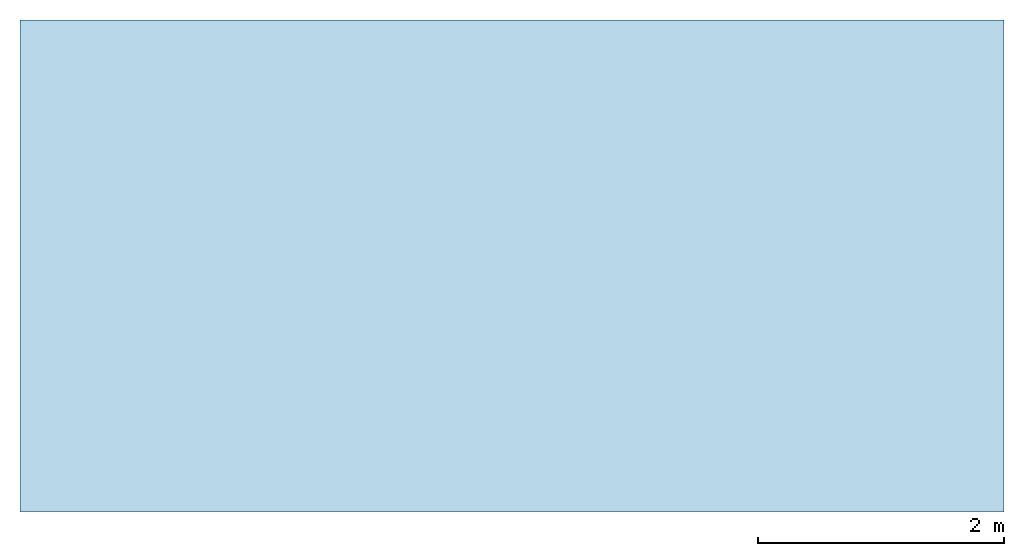
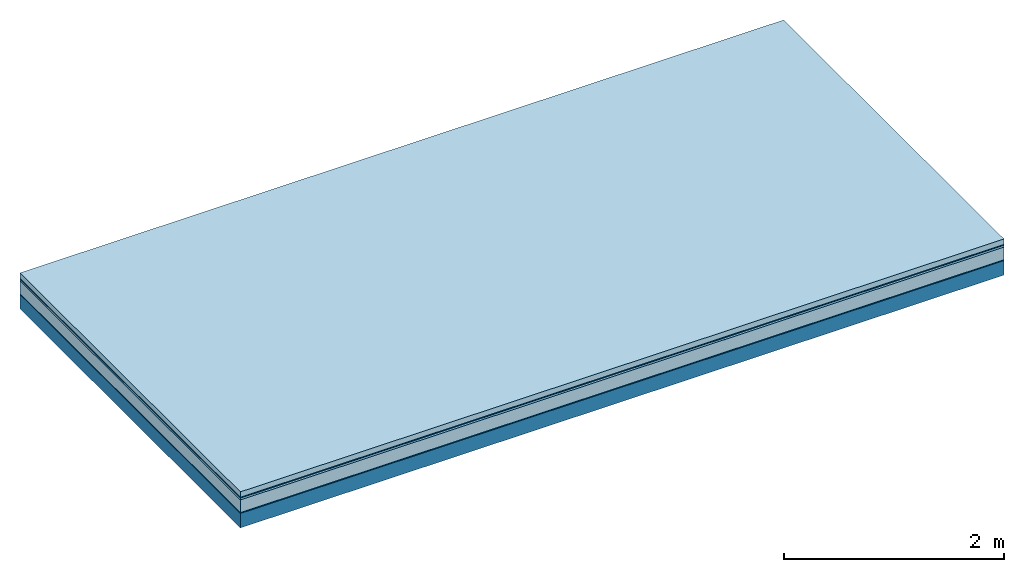
# One storey: 5 plates, 1 member, 1 element without a shape of its own.
"""IFC4 building model written with IfcOpenShell, lengths in metres."""

from ifc_helpers import new_model, si_unit, derived_unit, direction, frame, frame_2d, origin, origin_with_axes, place, context, project, spatial, rectangle, extrude, material, layer, layer_set, type_object, element, aggregate, save


model = new_model("IFC4")

# Units and contexts
plan_context = context("Plan", 3, precision=1e-05, world=origin(), true_north=direction((0.0, 1.0)))
model_context = context("Model", 3, precision=1e-05, world=origin(), true_north=direction((0.0, 1.0)))
ifc_project = project(units=[si_unit("LENGTHUNIT", "METRE"), derived_unit("SOUNDPRESSUREUNIT", [(si_unit("PRESSUREUNIT", "PASCAL", prefix="MICRO"), 0)]), si_unit("ENERGYUNIT", "JOULE", prefix="MEGA"), si_unit("MASSUNIT", "GRAM", prefix="KILO"), derived_unit("THERMALTRANSMITTANCEUNIT", [(si_unit("POWERUNIT", "WATT"), 1), (si_unit("AREAUNIT", "SQUARE_METRE"), -1), (si_unit("THERMODYNAMICTEMPERATUREUNIT", "KELVIN"), -1)]), derived_unit("AREADENSITYUNIT", [(si_unit("MASSUNIT", "GRAM", prefix="KILO"), 1), (si_unit("AREAUNIT", "SQUARE_METRE"), -1)]), derived_unit("USERDEFINED", [(si_unit("ENERGYUNIT", "JOULE", prefix="MEGA"), 1), (si_unit("AREAUNIT", "SQUARE_METRE"), -1)])], contexts=[plan_context, model_context])

# Site, building, storey
site = spatial("IfcSite", under=ifc_project)
building_placement = place(None, origin())
building = spatial("IfcBuilding", under=site, at=building_placement)
storey_placement = place(building_placement, origin())
storey = spatial("IfcBuildingStorey", under=building, at=storey_placement)

# Slab, member, plates
ifc_material_1 = material(Name="clay", Category="02.004")
ifc_layer_1 = layer(ifc_material_1, 0.06, Name="Use and protection layer 2")
ifc_material_2 = material(Name="Protective layer", Category="09.007")
ifc_layer_2 = layer(ifc_material_2, 0.01, Name="Use and protection layer 1")
ifc_material_3 = material(Name="Bituminous", Category="09.003")
ifc_layer_3 = layer(ifc_material_3, 0.02, Name="Seal")
ifc_material_4 = material(Name="Mineral wool", Category="10.008")
ifc_layer_4 = layer(ifc_material_4, 0.14, Name="Exterior insulation layer 1")
ifc_material_5 = material(Name="Vapor-permeable barrier", Category="09.006")
ifc_layer_5 = layer(ifc_material_5, 0.01, Name="layer / temporary roof")
ifc_material_6 = material(Name="no composite action")
ifc_layer_6 = layer(ifc_material_6, 0.0, Name="Bond")
ifc_layer_7 = layer(None, 0.16, Name="Support")
ifc_layer_set = layer_set([ifc_layer_1, ifc_layer_2, ifc_layer_3, ifc_layer_4, ifc_layer_5, ifc_layer_6, ifc_layer_7])
slab_type = type_object("IfcSlabType", Name="F0053", PredefinedType="NOTDEFINED", material=ifc_layer_set)
slab_placement = place(None, frame((0.0, 0.0, 0.0), z_axis=(0.0, 0.0, -1.0), x_axis=(1.0, 0.0, 0.0)))
slab = element("IfcSlab", 1, at=slab_placement, inside=storey, type_object=slab_type, material=ifc_layer_set, Name="Slab #1")
ifc_material_7 = material(Name="Solid timber panel")
member_placement = place(slab_placement, origin())
member = element("IfcMember", 2, at=member_placement, material=ifc_material_7, Name="Support", context=plan_context, shape_type="SweptSolid", body=[
    extrude(rectangle(XDim=1.0, YDim=0.16, at=frame_2d((0.5, 0.08), x_axis=(1.0, 0.0))), frame((0.0, 4.0, 0.24), z_axis=(0.0, -1.0, 0.0), x_axis=(1.0, 0.0, 0.0)), (0.0, 0.0, 1.0), 4.0),
    extrude(rectangle(XDim=1.0, YDim=0.16, at=frame_2d((0.5, 0.08), x_axis=(1.0, 0.0))), frame((1.0, 4.0, 0.24), z_axis=(0.0, -1.0, 0.0), x_axis=(1.0, 0.0, 0.0)), (0.0, 0.0, 1.0), 4.0),
    extrude(rectangle(XDim=1.0, YDim=0.16, at=frame_2d((0.5, 0.08), x_axis=(1.0, 0.0))), frame((2.0, 4.0, 0.24), z_axis=(0.0, -1.0, 0.0), x_axis=(1.0, 0.0, 0.0)), (0.0, 0.0, 1.0), 4.0),
    extrude(rectangle(XDim=1.0, YDim=0.16, at=frame_2d((0.5, 0.08), x_axis=(1.0, 0.0))), frame((3.0, 4.0, 0.24), z_axis=(0.0, -1.0, 0.0), x_axis=(1.0, 0.0, 0.0)), (0.0, 0.0, 1.0), 4.0),
    extrude(rectangle(XDim=1.0, YDim=0.16, at=frame_2d((0.5, 0.08), x_axis=(1.0, 0.0))), frame((4.0, 4.0, 0.24), z_axis=(0.0, -1.0, 0.0), x_axis=(1.0, 0.0, 0.0)), (0.0, 0.0, 1.0), 4.0),
    extrude(rectangle(XDim=1.0, YDim=0.16, at=frame_2d((0.5, 0.08), x_axis=(1.0, 0.0))), frame((5.0, 4.0, 0.24), z_axis=(0.0, -1.0, 0.0), x_axis=(1.0, 0.0, 0.0)), (0.0, 0.0, 1.0), 4.0),
    extrude(rectangle(XDim=1.0, YDim=0.16, at=frame_2d((0.5, 0.08), x_axis=(1.0, 0.0))), frame((6.0, 4.0, 0.24), z_axis=(0.0, -1.0, 0.0), x_axis=(1.0, 0.0, 0.0)), (0.0, 0.0, 1.0), 4.0),
    extrude(rectangle(XDim=1.0, YDim=0.16, at=frame_2d((0.5, 0.08), x_axis=(1.0, 0.0))), frame((7.0, 4.0, 0.24), z_axis=(0.0, -1.0, 0.0), x_axis=(1.0, 0.0, 0.0)), (0.0, 0.0, 1.0), 4.0),
])
plate_1_placement = place(slab_placement, origin())
plate_1 = element("IfcPlate", 3, at=plate_1_placement, material=ifc_material_1, Name="Use and protection layer 2", context=plan_context, shape_type="SweptSolid", body=[
    extrude(rectangle(XDim=8.0, YDim=4.0, at=frame_2d((4.0, 2.0), x_axis=(1.0, 0.0))), origin_with_axes(), (0.0, 0.0, 1.0), 0.06),
])
plate_2_placement = place(slab_placement, origin())
plate_2 = element("IfcPlate", 4, at=plate_2_placement, material=ifc_material_2, Name="Use and protection layer 1", context=plan_context, shape_type="SweptSolid", body=[
    extrude(rectangle(XDim=8.0, YDim=4.0, at=frame_2d((4.0, 2.0), x_axis=(1.0, 0.0))), frame((0.0, 0.0, 0.06), z_axis=(0.0, 0.0, 1.0), x_axis=(1.0, 0.0, 0.0)), (0.0, 0.0, 1.0), 0.01),
])
plate_3_placement = place(slab_placement, origin())
plate_3 = element("IfcPlate", 5, at=plate_3_placement, material=ifc_material_3, Name="Seal", context=plan_context, shape_type="SweptSolid", body=[
    extrude(rectangle(XDim=8.0, YDim=4.0, at=frame_2d((4.0, 2.0), x_axis=(1.0, 0.0))), frame((0.0, 0.0, 0.07), z_axis=(0.0, 0.0, 1.0), x_axis=(1.0, 0.0, 0.0)), (0.0, 0.0, 1.0), 0.02),
])
plate_4_placement = place(slab_placement, origin())
plate_4 = element("IfcPlate", 6, at=plate_4_placement, material=ifc_material_4, Name="Exterior insulation layer 1", context=plan_context, shape_type="SweptSolid", body=[
    extrude(rectangle(XDim=8.0, YDim=4.0, at=frame_2d((4.0, 2.0), x_axis=(1.0, 0.0))), frame((0.0, 0.0, 0.09), z_axis=(0.0, 0.0, 1.0), x_axis=(1.0, 0.0, 0.0)), (0.0, 0.0, 1.0), 0.14),
])
plate_5_placement = place(slab_placement, origin())
plate_5 = element("IfcPlate", 7, at=plate_5_placement, material=ifc_material_5, Name="layer / temporary roof", context=plan_context, shape_type="SweptSolid", body=[
    extrude(rectangle(XDim=8.0, YDim=4.0, at=frame_2d((4.0, 2.0), x_axis=(1.0, 0.0))), frame((0.0, 0.0, 0.23), z_axis=(0.0, 0.0, 1.0), x_axis=(1.0, 0.0, 0.0)), (0.0, 0.0, 1.0), 0.01),
])
aggregate(slab, [plate_1, plate_2, plate_3, plate_4, plate_5, member])

save(model, "model.ifc")
